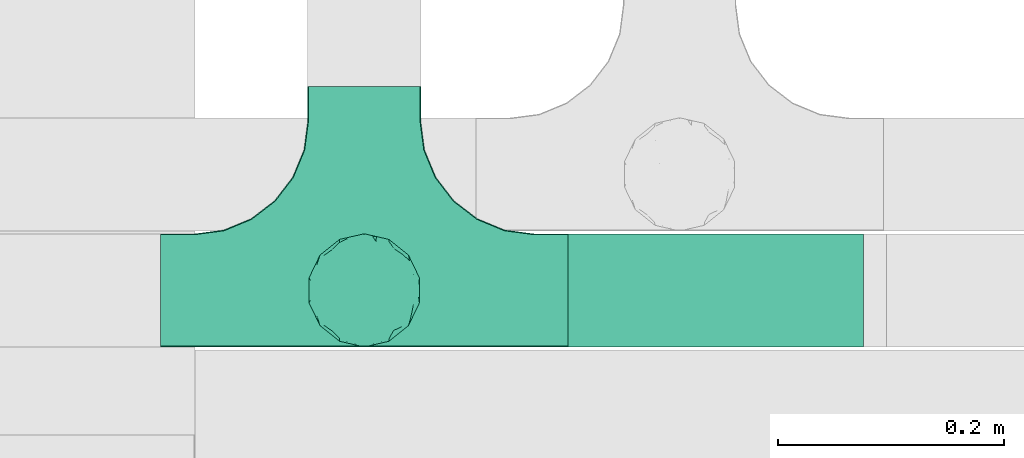
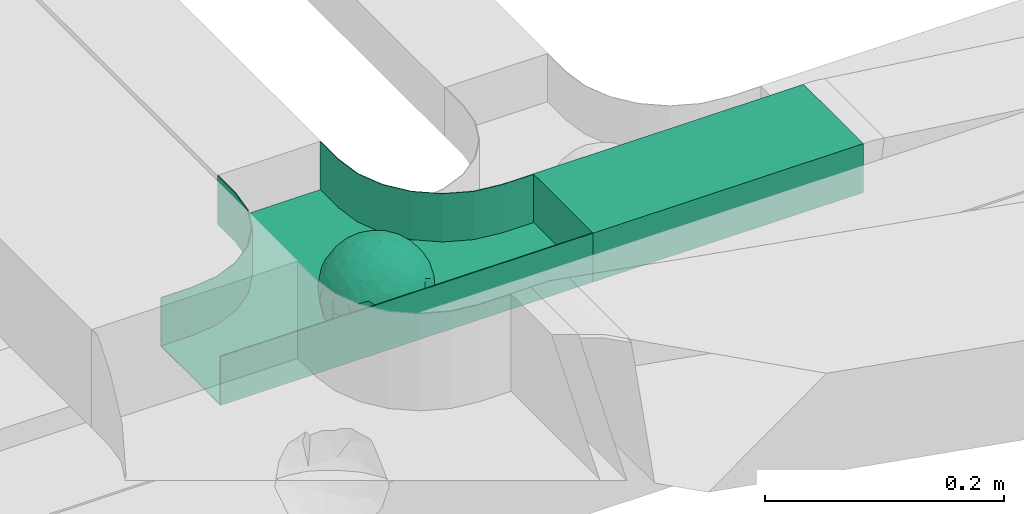
# One storey, part 15 of 38: 1 flow fitting, 1 flow segment.
"""IFC2X3 building model written with IfcOpenShell, lengths in millimetres."""

from ifc_helpers import new_model, entity, si_unit, converted_unit, derived_unit, direction, frame, frame_2d, origin, place, context, subcontext, project, spatial, rectangle, extrude, faceted_brep, source, transform, mapped, material, material_list, type_object, type_shapes, element, save


model = new_model("IFC2X3")

# Units and contexts
model_context = context("Model", 3, precision=0.01, world=origin(), true_north=direction((6.12303176911189e-17, 1.0)))
body_context = subcontext(model_context, "Body", "Model", "MODEL_VIEW")
ifc_project = project(units=[si_unit("LENGTHUNIT", "METRE", prefix="MILLI"), si_unit("AREAUNIT", "SQUARE_METRE"), si_unit("VOLUMEUNIT", "CUBIC_METRE"), converted_unit("PLANEANGLEUNIT", "DEGREE", entity("IfcRatioMeasure", 0.0174532925199433), si_unit("PLANEANGLEUNIT", "RADIAN"), dimensions=[0, 0, 0, 0, 0, 0, 0]), si_unit("MASSUNIT", "GRAM", prefix="KILO"), derived_unit("MASSDENSITYUNIT", [(si_unit("MASSUNIT", "GRAM", prefix="KILO"), 1), (si_unit("LENGTHUNIT", "METRE"), -3)]), derived_unit("MOMENTOFINERTIAUNIT", [(si_unit("LENGTHUNIT", "METRE"), 4)]), si_unit("TIMEUNIT", "SECOND"), si_unit("FREQUENCYUNIT", "HERTZ"), si_unit("THERMODYNAMICTEMPERATUREUNIT", "DEGREE_CELSIUS"), derived_unit("THERMALTRANSMITTANCEUNIT", [(si_unit("MASSUNIT", "GRAM", prefix="KILO"), 1), (si_unit("THERMODYNAMICTEMPERATUREUNIT", "KELVIN"), -1), (si_unit("TIMEUNIT", "SECOND"), -3)]), derived_unit("VOLUMETRICFLOWRATEUNIT", [(si_unit("LENGTHUNIT", "METRE"), 3), (si_unit("TIMEUNIT", "SECOND"), -1)]), derived_unit("MASSFLOWRATEUNIT", [(si_unit("MASSUNIT", "GRAM", prefix="KILO"), 1), (si_unit("TIMEUNIT", "SECOND"), -1)]), derived_unit("ROTATIONALFREQUENCYUNIT", [(si_unit("TIMEUNIT", "SECOND"), -1)]), si_unit("ELECTRICCURRENTUNIT", "AMPERE"), si_unit("ELECTRICVOLTAGEUNIT", "VOLT"), si_unit("POWERUNIT", "WATT"), si_unit("FORCEUNIT", "NEWTON", prefix="KILO"), si_unit("ILLUMINANCEUNIT", "LUX"), si_unit("LUMINOUSFLUXUNIT", "LUMEN"), si_unit("LUMINOUSINTENSITYUNIT", "CANDELA"), derived_unit("USERDEFINED", [(si_unit("MASSUNIT", "GRAM", prefix="KILO"), -1), (si_unit("LENGTHUNIT", "METRE"), -2), (si_unit("TIMEUNIT", "SECOND"), 3), (si_unit("LUMINOUSFLUXUNIT", "LUMEN"), 1)]), derived_unit("LINEARVELOCITYUNIT", [(si_unit("LENGTHUNIT", "METRE"), 1), (si_unit("TIMEUNIT", "SECOND"), -1)]), si_unit("PRESSUREUNIT", "PASCAL"), derived_unit("USERDEFINED", [(si_unit("LENGTHUNIT", "METRE"), -2), (si_unit("MASSUNIT", "GRAM", prefix="KILO"), 1), (si_unit("TIMEUNIT", "SECOND"), -2)]), derived_unit("LINEARFORCEUNIT", [(si_unit("MASSUNIT", "GRAM", prefix="KILO"), 1), (si_unit("LENGTHUNIT", "METRE"), 1), (si_unit("TIMEUNIT", "SECOND"), -2), (si_unit("LENGTHUNIT", "METRE"), -1)]), derived_unit("PLANARFORCEUNIT", [(si_unit("MASSUNIT", "GRAM", prefix="KILO"), 1), (si_unit("LENGTHUNIT", "METRE"), 1), (si_unit("TIMEUNIT", "SECOND"), -2), (si_unit("LENGTHUNIT", "METRE"), -2)])], contexts=[model_context])

# Site, building, storey
site_placement = place(None, frame((0.0, -0.00077364408347762, 0.0)))
site = spatial("IfcSite", under=ifc_project, at=site_placement, CompositionType="ELEMENT")
building_placement = place(site_placement, origin())
building = spatial("IfcBuilding", under=site, at=building_placement, CompositionType="ELEMENT")
storey_placement = place(building_placement, frame((0.0, 0.0, 4200.0)))
storey = spatial("IfcBuildingStorey", under=building, at=storey_placement, CompositionType="ELEMENT", Elevation=4200.0)

# Flow segment
cable_carrier_segment_type = type_object("IfcCableCarrierSegmentType", PredefinedType="CABLETRAYSEGMENT")
flow_segment_placement = place(storey_placement, frame((15013.0702916723, 11851.5299176424, 2820.0)))
element("IfcFlowSegment", 1, at=flow_segment_placement, inside=storey, type_object=cable_carrier_segment_type, context=body_context, shape_type="SweptSolid", body=[
    extrude(rectangle(XDim=261.171388914031, YDim=99.9999999999989, at=frame_2d((1.08002495835535e-12, 0.0), x_axis=(1.0, 0.0))), frame((130.585694457014, 50.0, 0.0)), (0.0, 0.0, 1.0), 49.9999999999995),
])

# Flow fitting
ifc_material_1 = material()
ifc_material_2 = material()
ifc_material_list = material_list([ifc_material_1, ifc_material_2])
cable_carrier_fitting_type = type_object("IfcCableCarrierFittingType", PredefinedType="NOTDEFINED", material=ifc_material_1)
shared_shape = source(origin(), body_context, "Body", "Brep", [
    faceted_brep([(43.65414201495, -13.6159823941412, -20.221792907194), (44.7734537304832, 0.0, -22.2561865791168), (48.2627667869764, -5.5982238187369, -11.8053052540677), (16.6591030416451, 5.32882774998004, -46.8409850521773), (11.5556000970565, -8.32997143460759, -47.9278591457525), (2.01883462715812, 2.6979389970297, -49.8863250993269), (-7.81264210311725, -35.946586740035, -33.8645171988286), (-17.2052206683237, -38.2719861359275, -27.1888848422606), (-11.1277274207927, -27.3202044092451, -40.3705352142543), (37.7030088371667, -7.24923843471304, -32.0301680723234), (10.6384317789277, 26.5155476513889, -41.0335168128579), (19.2127839264957, 19.8412508508062, -41.6796556903778), (10.4192511908907, 17.8098221318595, -45.5439286870577), (48.7463956090969, 0.0, 0.0), (48.0667721403428, 6.51594663441988, -12.1296271775358), (-37.4554170352858, 12.1627069007925, -30.8084451986326), (-31.3452178059555, 12.1462454498318, -37.0127821457472), (-38.0909108580228, 3.52194087904066, -32.1974912446565), (48.7463956090969, 11.1260466978072, 0.0), (9.66670567763161, 42.5651334019307, -24.3877883338551), (17.4761229293595, 37.974251726212, -27.4324868211278), (8.3452685270067, 35.3634447252368, -34.3479733081336), (36.7018152786982, 20.4309971840494, -27.121045505536), (28.2201055605836, 12.5803931374896, -39.3110588849404), (28.3969378462537, 24.0066360557188, -33.4259681422047), (37.1036906899333, 7.75177236926259, -32.6071489449891), (30.3928805396455, 38.1114667440203, 0.0), (34.7422273315263, 34.6429784184742, 0.0), (32.9402906787036, 32.1278050479557, -19.5637775698511), (26.0435337477646, 41.5799550695664, 0.0), (-44.7734518080776, 0.0, -22.2561904464559), (-35.9183276906112, -8.71634506105637, -33.6734177755349), (-42.698067512074, -12.1858404892465, -22.9865247983333), (5.42354673897514, -48.7621108487887, 0.0), (2.92058716488888e-07, -48.7843224693665, -10.9585528791684), (7.58713024513234, -47.4313421101439, -13.8817592643935), (33.995370401777, -31.6485911362954, -18.5116576873667), (40.0066375577234, -26.2448741379086, -14.5146661281262), (30.3928805396453, -38.1114667440373, 0.0), (-47.5540080368347, -8.6499737676748, -12.798213682019), (43.918984866252, -21.1502683953847, 0.0), (-47.5463631702337, 8.67950108284767, -12.8066236860544), (-43.9189848662407, 21.1502683953677, 0.0), (-41.5587306666804, 23.544384411141, -14.7828910593852), (-36.7018137075475, 20.43099797302, -27.1210470373429), (-42.6812093094125, 12.162707383776, -23.0300438771125), (-0.0435489182880873, -44.6798423199703, -22.4434799831651), (43.3459115209922, 13.125713179152, -21.1860238825719), (-9.67158541810518, -42.815796006327, -23.9430166822217), (2.9348104480415, -38.3026865671621, -32.0045479482528), (10.5768620896568, -32.3565839798164, -36.6221444141874), (17.476122931187, -37.9742517249799, -27.4324868216925), (29.4150529887209, -14.2918330913411, -37.8219270339311), (29.2594402117981, 0.0, -40.5448536622337), (-34.742227331515, 34.6429784184742, 0.0), (-35.5934709721032, 30.8679809236437, -16.7413433706631), (16.2706402169142, 46.2863325463322, 0.0), (15.3978227309257, 45.3692296018892, -14.301750259225), (10.8470934779447, 47.524221697552, 0.0), (-22.0930685137321, 42.2576087042555, -15.0396419586498), (-16.2706402169028, 46.2863325463322, 0.0), (-15.3976096147999, 45.3685960862683, -14.3039892096614), (-35.5741674477324, -30.877857614309, -16.7641438657341), (-34.7422273315149, -34.6429784184913, 0.0), (-41.544749127214, -23.5699215759022, -14.7814957586296), (-21.2012609977656, -29.9118129495041, -33.9969113035032), (-22.0930685137892, -42.2576087036302, -15.0396419603704), (-28.5890959469058, -35.7745555449591, -20.0709932115786), (27.967317375364, -26.9235432392394, -31.5111405422078), (26.5630985649032, -36.7540375314827, -21.0604491824418), (-4.69743067705244, -12.8233951627736, -48.0988012484001), (-3.71385705669819, -22.0483048804436, -44.7222485756373), (7.046128924104e-07, -29.8515321197025, -40.1109215813634), (-8.78090686085946, 23.4705297392872, -43.266960933916), (-10.7087237416586, 12.1533783795858, -47.3034737602475), (-19.1851128431225, 19.8122800241045, -41.7061746680507), (19.2127839279743, -19.841250849511, -41.6796556903208), (10.2736167511021, -43.2535488218696, -22.8819429499797), (-16.2706402169027, -46.2863325463492, 0.0), (-15.4179487650123, -45.4307793041134, -14.0830091848577), (-10.8470934779332, -47.524221697569, 0.0), (-21.6941869558721, -45.0484433951294, 0.0), (-26.043533747753, -41.5799550695834, 0.0), (-30.3928805396339, -38.1114667440373, 0.0), (-26.9077773704145, -11.7097120961444, -40.4827637348157), (-28.5735237959864, -22.531789977659, -34.2909926698312), (-14.3485559949731, 0.554718003800719, -47.8937493708156), (20.3912706461748, 29.6966950280778, -34.6742323035854), (25.8798715159051, 35.5620355309087, -23.7817972243053), (-1.90439589452332, 38.2956374757213, -32.090768557389), (-0.0435489197807358, 44.6798423204566, -22.4434799821603), (-9.54280395759116, 42.6678856642021, -24.2566779582937), (-10.1209262269152, 33.0365306692783, -36.140759450321), (-17.2052206685055, 38.2719861378047, -27.1888848394794), (-28.5890959468196, 35.7745555453602, -20.0709932109564), (-30.3928805396341, 38.1114667440203, 0.0), (-26.0435337477532, 41.5799550695664, 0.0), (-21.6941869558723, 45.0484433951125, 0.0), (0.920553890736952, 16.9936143333855, -47.0145685125519), (7.01705705346737e-07, 29.8515321215381, -40.1109215799846), (-28.4299335912282, 23.6392950735915, -33.6589156750601), (22.0754283900311, -42.7194435884069, -13.7012627481666), (0.0, -50.0, 0.0), (-7.98433520770671, 47.2879675743241, -14.1456181900809), (-10.8470934779333, 47.524221697552, 0.0), (-5.42354673896381, 48.7621108487718, 0.0), (-39.0915741233958, -31.1744900929452, 0.0), (-36.7018137083218, -20.4309979729983, -27.1210470363242), (-20.0503020227076, 29.8835350153312, -34.7125297808217), (48.7463956090969, -11.1260466978243, 0.0), (36.7018152787698, -20.430997183803, -27.1210455056374), (39.0915741234071, -31.1744900929452, 0.0), (43.9189848662521, 21.1502683953677, 0.0), (41.0372234357161, 24.481336168204, -14.7176924857918), (21.4315363761966, -9.86715979165204, -44.0831986838696), (19.8461085062156, -30.3026908878047, -34.4656191315041), (26.0435337477644, -41.5799550695834, 0.0), (8.27678352490751, -22.6176025005053, -43.8171075221857), (-19.1851128386707, -19.8122800229913, -41.7061746706354), (-17.559283921422, -9.66340012518247, -45.8070982074481), (-29.2594384269524, -1.64502744759432e-09, -40.5448549502702), (-22.2759109836818, 8.45458562997746, -43.957977338265), (21.6941869558835, -45.0484433951294, 0.0), (-7.7537430917927, -47.3248906716555, -14.1504131029038), (22.0929359888287, 42.3611643932195, -14.7456410726513), (21.6941869558837, 45.0484433951125, 0.0), (7.94480963874029, 47.2524194975214, -14.285966940796), (5.42354673897518, 48.7621108487718, 0.0), (-43.9189848662406, -21.1502683953848, 0.0), (-39.0915741233959, 31.1744900929281, 0.0), (-48.7463956090855, 11.1260466978072, 0.0), (-48.7463956090855, -11.1260466978243, 0.0), (-48.7463956090855, 0.0, 0.0), (0.0, 50.0, 0.0), (2.95674852821199e-07, 48.76542105366, -11.0423597776141), (-5.42354673896377, -48.7621108487887, 0.0), (16.2706402169141, -46.2863325463492, 0.0), (10.8470934779446, -47.524221697569, 0.0), (39.0915741234072, 31.1744900929281, 0.0), (34.7422273315262, -34.6429784184913, 0.0), (-43.6541417785539, -13.6159824952714, 20.2217933494142), (-44.7734534735007, 0.0, 22.2561870960884), (-48.2627667188257, -5.59822380837423, 11.8053055375658), (-16.6591016552529, 5.32882757852047, 46.8409855647676), (-11.5555985538933, -8.32997141356845, 47.9278595214841), (-2.01883285210585, 2.69793886619285, 49.8863251782511), (7.81264298940045, -35.9465866899564, 33.8645170475355), (17.2052219498432, -38.2719853643866, 27.1888851173795), (11.1277291939633, -27.3202042660781, 40.370534822402), (-37.7030082707847, -7.24923849358482, 32.0301687256941), (-10.6384306361632, 26.5155474098453, 41.0335172652288), (-19.2127828542464, 19.8412506695278, 41.6796562709507), (-10.419249902145, 17.8098220464058, 45.5439290153173), (-48.0667720467311, 6.51594672713361, 12.1296274986609), (37.4554198551597, 12.1627053911885, 30.8084423663635), (31.3452204336626, 12.1462444514283, 37.0127802480704), (38.0909129847824, 3.52193921618223, 32.1974889105362), (-9.66670492251031, 42.565133342123, 24.3877887375616), (-17.4761222809685, 37.9742516795029, 27.4324872988574), (-8.34526747232003, 35.3634445391436, 34.3479737559899), (-36.7018147879525, 20.4309972885889, 27.1210460908894), (-28.2201045883605, 12.5803929822385, 39.3110596325575), (-28.3969371324566, 24.0066357536882, 33.4259689655335), (-37.1036900366786, 7.75177247673037, 32.6071496627812), (-32.9402901163369, 32.1278052689131, 19.5637781538672), (44.773453728735, 0.0, 22.2561865826485), (35.9183286182219, -8.71634518545332, 33.6734167539099), (42.6980684782056, -12.1858381773451, 22.9865242293622), (-5.1564557811304e-08, -48.7843224155168, 10.9585531189064), (-7.58712982046247, -47.4313421866568, 13.8817592350767), (-33.9953700157816, -31.6485912778883, 18.5116581541388), (-40.0066373233245, -26.2448743223541, 14.5146664406737), (47.5540088657557, -8.64997340643016, 12.7982108462298), (47.5463641063755, 8.67950029611492, 12.8066207437518), (41.5587323717035, 23.5443822102692, 14.7828897714275), (36.7018153946169, 20.4309968399072, 27.121045607934), (42.6812105193328, 12.1627054070682, 23.0300426787683), (0.0435498934198039, -44.6798421141237, 22.4434803910813), (-43.3459112327239, 13.1257132261269, 21.1860244432478), (9.6715868653752, -42.8157959611257, 23.9430161784588), (-2.93481023367521, -38.3026862522726, 32.0045483447802), (-10.5768615382775, -32.3565831315815, 36.6221453228799), (-17.4761222811971, -37.9742516793303, 27.4324872989742), (-29.4150522011614, -14.2918331221065, 37.8219276348162), (-29.259439267976, 0.0, 40.5448543433553), (35.593472529025, 30.867979902287, 16.7413419437535), (-15.3978225621776, 45.3692295068837, 14.3017507422931), (22.0930688164668, 42.2576085856364, 15.0396418472572), (15.3976099169387, 45.3685960801975, 14.3039889037045), (35.5741692798952, -30.8778564526781, 16.7641421174582), (41.5447510295928, -23.5699190140567, 14.7814944968718), (21.2012629219892, -29.9118119699372, 33.9969109653959), (22.0930688164889, -42.2576085855628, 15.039641847479), (28.5890966709526, -35.7745557157875, 20.0709918757936), (-27.9673166448933, -26.9235432178776, 31.5111412087844), (-26.5630981091642, -36.7540374223405, 21.0604499477277), (4.69743244094294, -12.8233948182002, 48.0988011680158), (3.71385918047916, -22.0483045188225, 44.7222485775695), (6.0892732202368e-07, -29.8515316280668, 40.1109219472655), (8.78090833347225, 23.4705290601204, 43.2669610034903), (10.7087255323208, 12.1533779204354, 47.3034734728551), (19.1851144535653, 19.8122792782791, 41.7061742815566), (-19.212782854423, -19.8412506693283, 41.6796562709723), (-10.2736163541564, -43.2535491498667, 22.8819425082012), (15.4179491053271, -45.430779442795, 14.0830083649343), (26.9077783310918, -11.7097109554472, 40.4827634262511), (28.5735255699879, -22.531788297607, 34.2909922955619), (14.3485579041194, 0.554717908736034, 47.893748799971), (-20.3912698186306, 29.6966949125693, 34.674232889184), (-25.8798708903081, 35.5620354347035, 23.7817980489561), (1.90439718168615, 38.2956370656312, 32.0907689704016), (0.0435498935700709, 44.6798421141929, 22.4434803909095), (9.54280511870019, 42.6678852802435, 24.2566781769111), (10.1209277017953, 33.036529901429, 36.1407597392074), (17.2052219497738, 38.2719853646937, 27.1888851169673), (28.5890966709116, 35.7745557157488, 20.0709918758907), (-0.920552500958269, 16.993613961591, 47.0145686741652), (6.09264554473049e-07, 29.8515316283504, 40.1109219470418), (28.4299352793349, 23.6392936643312, 33.6589152389788), (-22.0754282965694, -42.7194435788052, 13.7012629286858), (7.9843354212563, 47.2879674404261, 14.1456185171795), (36.7018153946056, -20.4309968401043, 27.1210456078136), (20.0503035663584, 29.8835340747136, 34.7125296989797), (-36.7018147879654, -20.4309972885437, 27.1210460909186), (-41.0372232425556, 24.4813362747081, 14.7176928472045), (-21.4315352776288, -9.8671595900376, 44.0831992630873), (-19.8461080318002, -30.3026912052829, 34.4656191255603), (-8.27678185920825, -22.617601585775, 43.8171083090061), (19.1851144530605, -19.8122792780652, 41.7061742818985), (17.5592847966676, -9.6634000411993, 45.8070978896755), (29.259440221343, 0.0, 40.5448536553604), (22.2759127990671, 8.45458631346954, 43.9579762868721), (7.75374356219277, -47.3248906381916, 14.1504129570858), (-22.0929358819219, 42.3611643749655, 14.7456412852645), (-7.94480944914509, 47.2524194744515, 14.2859671225497), (-5.23333520595152e-08, 48.7654210084985, 11.0423599770715)], [[[0, 1, 2]], [[3, 4, 5]], [[6, 7, 8]], [[1, 0, 9]], [[10, 11, 12]], [[13, 2, 14]], [[15, 16, 17]], [[14, 18, 13]], [[19, 20, 21]], [[22, 23, 24]], [[1, 9, 25]], [[26, 27, 28, 29]], [[30, 31, 32]], [[33, 34, 35]], [[36, 37, 38]], [[32, 39, 30]], [[2, 40, 0]], [[23, 22, 25]], [[41, 42, 43]], [[44, 15, 45]], [[46, 35, 34]], [[25, 22, 47]], [[31, 30, 17]], [[48, 49, 46]], [[50, 51, 49]], [[52, 53, 9]], [[43, 54, 55]], [[56, 57, 58]], [[59, 60, 61]], [[62, 63, 64]], [[8, 7, 65]], [[7, 66, 67]], [[68, 36, 69]], [[70, 5, 4]], [[8, 71, 72]], [[73, 74, 75]], [[68, 76, 52]], [[77, 46, 49]], [[78, 79, 80]], [[7, 6, 48]], [[67, 81, 82, 83]], [[84, 85, 31]], [[85, 65, 67]], [[70, 86, 5]], [[23, 3, 11]], [[21, 87, 10]], [[21, 20, 87]], [[28, 24, 88]], [[19, 89, 90]], [[91, 90, 89]], [[91, 92, 93]], [[94, 95, 96, 97]], [[98, 99, 10]], [[100, 16, 44]], [[77, 51, 101]], [[33, 102, 34]], [[103, 91, 61]], [[93, 59, 61]], [[104, 105, 103]], [[106, 64, 63]], [[107, 31, 85]], [[100, 94, 108]], [[108, 93, 92]], [[43, 55, 44]], [[0, 40, 37]], [[2, 13, 109]], [[2, 1, 14]], [[110, 9, 0]], [[2, 109, 40]], [[37, 40, 111]], [[47, 14, 1]], [[112, 14, 47]], [[113, 112, 47]], [[112, 18, 14]], [[47, 22, 113]], [[52, 9, 110]], [[53, 25, 9]], [[25, 47, 1]], [[23, 25, 53]], [[68, 52, 110]], [[76, 4, 114]], [[51, 115, 69]], [[50, 115, 51]], [[110, 36, 68]], [[3, 23, 53]], [[23, 11, 24]], [[52, 76, 114]], [[98, 12, 5]], [[11, 87, 24]], [[24, 28, 22]], [[87, 88, 24]], [[36, 116, 69]], [[28, 27, 113]], [[114, 3, 53]], [[76, 115, 117]], [[70, 4, 117]], [[118, 84, 119]], [[119, 70, 118]], [[120, 16, 121]], [[37, 36, 110]], [[116, 36, 38]], [[116, 122, 69]], [[34, 123, 46]], [[10, 87, 11]], [[87, 20, 88]], [[12, 98, 10]], [[10, 99, 21]], [[74, 5, 86]], [[73, 75, 108]], [[124, 56, 125]], [[124, 29, 88]], [[89, 21, 99]], [[21, 89, 19]], [[92, 89, 99]], [[89, 92, 91]], [[126, 127, 58]], [[88, 29, 28]], [[20, 57, 124]], [[88, 20, 124]], [[57, 20, 19]], [[73, 92, 99]], [[92, 73, 108]], [[99, 98, 73]], [[74, 86, 121]], [[73, 98, 74]], [[5, 74, 98]], [[100, 108, 75]], [[94, 93, 108]], [[86, 120, 121]], [[100, 44, 55]], [[75, 16, 100]], [[17, 16, 120]], [[31, 17, 120]], [[17, 30, 45]], [[84, 31, 120]], [[31, 107, 32]], [[41, 45, 30]], [[43, 44, 45]], [[107, 64, 32]], [[39, 64, 128]], [[30, 39, 41]], [[129, 43, 42]], [[41, 130, 42]], [[43, 45, 41]], [[62, 83, 63]], [[95, 94, 55]], [[100, 55, 94]], [[64, 107, 62]], [[131, 39, 128]], [[64, 106, 128]], [[85, 62, 107]], [[67, 83, 62]], [[39, 32, 64]], [[130, 41, 132]], [[59, 97, 60]], [[133, 127, 134]], [[59, 94, 97]], [[104, 61, 60]], [[94, 59, 93]], [[126, 134, 127]], [[126, 58, 57]], [[19, 90, 126]], [[134, 105, 133]], [[126, 90, 134]], [[103, 90, 91]], [[105, 134, 103]], [[90, 103, 134]], [[119, 120, 86]], [[84, 118, 85]], [[65, 85, 118]], [[62, 85, 67]], [[8, 65, 118]], [[67, 65, 7]], [[71, 118, 70]], [[8, 72, 6]], [[49, 6, 72]], [[6, 49, 48]], [[50, 49, 72]], [[77, 49, 51]], [[101, 69, 122]], [[123, 34, 135]], [[101, 122, 136]], [[137, 77, 136]], [[78, 81, 66]], [[7, 79, 66]], [[67, 66, 81]], [[79, 7, 48]], [[35, 137, 33]], [[123, 80, 79]], [[135, 34, 102]], [[35, 46, 77]], [[80, 123, 135]], [[46, 123, 48]], [[117, 50, 72]], [[115, 76, 68]], [[117, 72, 71]], [[4, 76, 117]], [[39, 132, 41]], [[39, 131, 132]], [[137, 35, 77]], [[124, 57, 56]], [[126, 57, 19]], [[103, 61, 104]], [[61, 91, 93]], [[77, 101, 136]], [[51, 69, 101]], [[28, 113, 22]], [[112, 113, 138]], [[16, 75, 121]], [[74, 121, 75]], [[66, 79, 78]], [[123, 79, 48]], [[0, 37, 110]], [[37, 111, 139, 38]], [[29, 124, 125]], [[115, 50, 117]], [[69, 115, 68]], [[120, 119, 84]], [[70, 119, 86]], [[11, 3, 12]], [[5, 12, 3]], [[118, 71, 8]], [[117, 71, 70]], [[3, 114, 4]], [[53, 52, 114]], [[27, 138, 113]], [[45, 15, 17]], [[44, 16, 15]], [[55, 54, 95]], [[43, 129, 54]], [[140, 141, 142]], [[143, 144, 145]], [[146, 147, 148]], [[141, 140, 149]], [[150, 151, 152]], [[132, 142, 153]], [[154, 155, 156]], [[153, 130, 132]], [[157, 158, 159]], [[160, 161, 162]], [[141, 149, 163]], [[95, 54, 164, 96]], [[165, 166, 167]], [[135, 168, 169]], [[170, 171, 83]], [[167, 172, 165]], [[142, 141, 153]], [[161, 160, 163]], [[173, 112, 174]], [[175, 154, 176]], [[177, 169, 168]], [[163, 160, 178]], [[166, 165, 156]], [[179, 180, 177]], [[181, 182, 180]], [[183, 184, 149]], [[174, 27, 185]], [[60, 186, 104]], [[187, 56, 188]], [[189, 139, 190]], [[148, 147, 191]], [[147, 192, 193]], [[194, 170, 195]], [[196, 145, 144]], [[148, 197, 198]], [[199, 200, 201]], [[194, 202, 183]], [[203, 177, 180]], [[136, 204, 137]], [[147, 146, 179]], [[193, 122, 116, 38]], [[205, 206, 166]], [[206, 191, 193]], [[196, 207, 145]], [[161, 143, 151]], [[159, 208, 150]], [[159, 158, 208]], [[164, 162, 209]], [[157, 210, 211]], [[212, 211, 210]], [[212, 213, 214]], [[215, 26, 29, 125]], [[216, 217, 150]], [[218, 155, 175]], [[203, 182, 219]], [[135, 102, 168]], [[220, 212, 188]], [[214, 187, 188]], [[58, 127, 220]], [[111, 190, 139]], [[221, 166, 206]], [[218, 215, 222]], [[222, 214, 213]], [[174, 185, 175]], [[171, 140, 128]], [[132, 131, 142]], [[142, 128, 140]], [[223, 149, 140]], [[142, 131, 128]], [[171, 128, 106]], [[178, 153, 141]], [[42, 153, 178]], [[224, 42, 178]], [[42, 130, 153]], [[178, 160, 224]], [[183, 149, 223]], [[184, 163, 149]], [[163, 178, 141]], [[161, 163, 184]], [[194, 183, 223]], [[202, 144, 225]], [[182, 226, 195]], [[181, 226, 182]], [[223, 170, 194]], [[143, 161, 184]], [[161, 151, 162]], [[183, 202, 225]], [[216, 152, 145]], [[151, 208, 162]], [[162, 164, 160]], [[208, 209, 162]], [[170, 82, 195]], [[164, 54, 224]], [[225, 143, 184]], [[202, 226, 227]], [[196, 144, 227]], [[228, 205, 229]], [[229, 196, 228]], [[230, 155, 231]], [[171, 170, 223]], [[82, 170, 83]], [[82, 81, 195]], [[168, 232, 177]], [[150, 208, 151]], [[208, 158, 209]], [[152, 216, 150]], [[150, 217, 159]], [[200, 145, 207]], [[199, 201, 222]], [[233, 60, 97]], [[233, 96, 209]], [[210, 159, 217]], [[159, 210, 157]], [[213, 210, 217]], [[210, 213, 212]], [[234, 105, 104]], [[209, 96, 164]], [[158, 186, 233]], [[209, 158, 233]], [[186, 158, 157]], [[199, 213, 217]], [[213, 199, 222]], [[217, 216, 199]], [[200, 207, 231]], [[199, 216, 200]], [[145, 200, 216]], [[218, 222, 201]], [[215, 214, 222]], [[207, 230, 231]], [[218, 175, 185]], [[201, 155, 218]], [[156, 155, 230]], [[166, 156, 230]], [[156, 165, 176]], [[205, 166, 230]], [[166, 221, 167]], [[173, 176, 165]], [[174, 175, 176]], [[221, 190, 167]], [[172, 190, 40]], [[165, 172, 173]], [[138, 174, 112]], [[173, 18, 112]], [[174, 176, 173]], [[189, 38, 139]], [[26, 215, 185]], [[218, 185, 215]], [[190, 221, 189]], [[109, 172, 40]], [[190, 111, 40]], [[206, 189, 221]], [[193, 38, 189]], [[172, 167, 190]], [[18, 173, 13]], [[187, 125, 56]], [[133, 105, 235]], [[187, 215, 125]], [[58, 188, 56]], [[215, 187, 214]], [[234, 235, 105]], [[234, 104, 186]], [[157, 211, 234]], [[235, 127, 133]], [[234, 211, 235]], [[220, 211, 212]], [[127, 235, 220]], [[211, 220, 235]], [[229, 230, 207]], [[205, 228, 206]], [[191, 206, 228]], [[189, 206, 193]], [[148, 191, 228]], [[193, 191, 147]], [[197, 228, 196]], [[148, 198, 146]], [[180, 146, 198]], [[146, 180, 179]], [[181, 180, 198]], [[203, 180, 182]], [[219, 195, 81]], [[232, 168, 33]], [[219, 81, 78]], [[80, 203, 78]], [[136, 122, 192]], [[147, 204, 192]], [[193, 192, 122]], [[204, 147, 179]], [[169, 80, 135]], [[232, 137, 204]], [[33, 168, 102]], [[169, 177, 203]], [[137, 232, 33]], [[177, 232, 179]], [[227, 181, 198]], [[226, 202, 194]], [[227, 198, 197]], [[144, 202, 227]], [[172, 13, 173]], [[172, 109, 13]], [[80, 169, 203]], [[233, 186, 60]], [[234, 186, 157]], [[220, 188, 58]], [[188, 212, 214]], [[203, 219, 78]], [[182, 195, 219]], [[164, 224, 160]], [[42, 224, 129]], [[155, 201, 231]], [[200, 231, 201]], [[192, 204, 136]], [[232, 204, 179]], [[140, 171, 223]], [[171, 106, 63, 83]], [[96, 233, 97]], [[226, 181, 227]], [[195, 226, 194]], [[230, 229, 205]], [[196, 229, 207]], [[151, 143, 152]], [[145, 152, 143]], [[228, 197, 148]], [[227, 197, 196]], [[143, 225, 144]], [[184, 183, 225]], [[54, 129, 224]], [[176, 154, 156]], [[175, 155, 154]], [[185, 27, 26]], [[174, 138, 27]]]),
    faceted_brep([(-53.4074173710859, -124.118095489752, 25.0), (-50.0, -150.0, 25.0), (-50.0, -180.0, 25.0), (-49.1999999999934, -180.0, 25.0), (-49.1999999999926, -150.0, 25.0), (-52.6346767100545, -123.91104025367, 25.0), (-62.7046392985216, -99.6000000000037, 25.0), (-78.7236364563899, -78.7236364563991, 25.0), (-99.5999999999949, -62.7046392985315, 25.0), (-123.911040253662, -52.6346767100651, 25.0), (-150.0, -49.2000000000047, 25.0), (-180.0, -49.2000000000047, 25.0), (-180.0, -50.0, 25.0), (-150.0, -50.0, 25.0), (-124.118095489745, -53.4074173710983, 25.0), (-100.0, -63.3974596215602, 25.0), (-79.2893218813398, -79.2893218813488, 25.0), (-63.3974596215496, -100.0, 25.0), (180.0, -50.0, 25.0), (180.0, -49.2000000000047, 25.0), (150.0, -49.2000000000046, 25.0), (123.911040253717, -52.634676710066, 25.0), (99.6000000000452, -62.7046392985316, 25.0), (78.7236364564342, -78.7236364563979, 25.0), (62.7046392985581, -99.6000000000012, 25.0), (52.6346767100809, -123.911040253668, 25.0), (49.200000000007, -150.0, 25.0), (49.2000000000071, -180.0, 25.0), (50.0, -180.0, 25.0), (50.0, -150.0, 25.0), (53.4074173711136, -124.11809548975, 25.0), (63.3974596215874, -100.0, 25.0), (79.2893218813853, -79.2893218813486, 25.0), (100.0, -63.3974596215613, 25.0), (124.1180954898, -53.4074173710999, 25.0), (150.0, -50.0, 25.0), (180.0, 49.1999999999958, 25.0), (180.0, 50.0, 25.0), (-180.0, 50.0, 25.0), (-180.0, 49.1999999999958, 25.0), (-180.0, -50.0, -25.0), (-180.0, 50.0, -25.0), (180.0, 50.0, -25.0), (180.0, -50.0, -25.0), (150.0, -50.0, -25.0), (124.1180954898, -53.4074173710999, -25.0), (100.0, -63.3974596215613, -25.0), (79.2893218813853, -79.2893218813486, -25.0), (63.3974596215874, -100.0, -25.0), (53.4074173711136, -124.11809548975, -25.0), (50.0, -150.0, -25.0), (50.0, -180.0, -25.0), (-50.0, -180.0, -25.0), (-50.0, -150.0, -25.0), (-53.4074173710859, -124.118095489752, -25.0), (-63.3974596215496, -100.0, -25.0), (-79.2893218813398, -79.2893218813488, -25.0), (-100.0, -63.3974596215602, -25.0), (-124.118095489745, -53.4074173710983, -25.0), (-150.0, -50.0, -25.0), (-50.0, -150.0, -24.199999999986), (49.2000000000071, -180.0, -24.199999999986), (-49.1999999999934, -180.0, -24.199999999986), (-49.1999999999926, -150.0, -24.199999999986), (-150.0, -49.2000000000047, -24.199999999986), (-180.0, -49.2000000000047, -24.199999999986), (180.0, -49.2000000000047, -24.199999999986), (150.0, -49.2000000000047, -24.199999999986), (-180.0, 49.1999999999958, -24.199999999986), (-150.0, -50.0, -24.199999999986), (150.0, -50.0, -24.199999999986), (180.0, 49.1999999999958, -24.199999999986), (49.200000000007, -150.0, -24.199999999986), (50.0, -150.0, -24.199999999986), (-123.911040253662, -52.6346767100651, -24.199999999986), (-99.5999999999949, -62.7046392985315, -24.199999999986), (-78.7236364563899, -78.7236364563991, -24.199999999986), (-62.7046392985217, -99.6000000000036, -24.199999999986), (-52.6346767100546, -123.91104025367, -24.199999999986), (52.6346767100807, -123.911040253669, -24.199999999986), (62.7046392985577, -99.6000000000018, -24.199999999986), (78.7236364564338, -78.7236364563983, -24.199999999986), (99.6000000000446, -62.704639298532, -24.199999999986), (123.911040253716, -52.6346767100662, -24.199999999986)], [[[0, 1, 2, 3, 4, 5, 6, 7, 8, 9, 10, 11, 12, 13, 14, 15, 16, 17]], [[18, 19, 20, 21, 22, 23, 24, 25, 26, 27, 28, 29, 30, 31, 32, 33, 34, 35]], [[36, 37, 38, 39]], [[40, 41, 42, 43, 44, 45, 46, 47, 48, 49, 50, 51, 52, 53, 54, 55, 56, 57, 58, 59]], [[2, 1, 60, 53, 52]], [[3, 2, 52, 51, 28, 27, 61, 62]], [[4, 3, 62, 63]], [[11, 10, 64, 65]], [[20, 19, 66, 67]], [[39, 38, 41, 40, 12, 11, 65, 68]], [[13, 12, 40, 59, 69]], [[18, 35, 70, 44, 43]], [[19, 18, 43, 42, 37, 36, 71, 66]], [[27, 26, 72, 61]], [[29, 28, 51, 50, 73]], [[38, 37, 42, 41]], [[36, 39, 68, 71]], [[68, 65, 64, 74, 75, 76, 77, 78, 63, 62, 61, 72, 79, 80, 81, 82, 83, 67, 66, 71]], [[14, 13, 69, 59, 58]], [[58, 57, 15, 14]], [[15, 57, 56, 16]], [[0, 17, 55, 54]], [[0, 54, 53, 60, 1]], [[55, 17, 16, 56]], [[5, 4, 63, 78]], [[6, 5, 78, 77]], [[7, 6, 77, 76]], [[8, 7, 76, 75]], [[9, 8, 75, 74]], [[10, 9, 74, 64]], [[21, 20, 67, 83]], [[22, 21, 83, 82]], [[23, 22, 82, 81]], [[81, 80, 24, 23]], [[24, 80, 79, 25]], [[79, 72, 26, 25]], [[30, 29, 73, 50, 49]], [[31, 30, 49, 48]], [[31, 48, 47, 32]], [[33, 32, 47, 46]], [[45, 34, 33, 46]], [[34, 45, 44, 70, 35]]]),
])
type_shapes(cable_carrier_fitting_type, [shared_shape])
flow_fitting_placement = place(storey_placement, frame((14833.0702916723, 11901.5299176424, 2845.0), z_axis=(0.0, 0.0, 1.0), x_axis=(-1.0, 0.0, 0.0)))
element("IfcFlowFitting", 2, at=flow_fitting_placement, inside=storey, type_object=cable_carrier_fitting_type, material=ifc_material_list, Name="470_DKC_S5_T", context=body_context, shape_type="MappedRepresentation", body=[
    mapped(shared_shape, transform((0.0, 0.0, 0.0), scale=1.0)),
])

save(model, "model.ifc")
